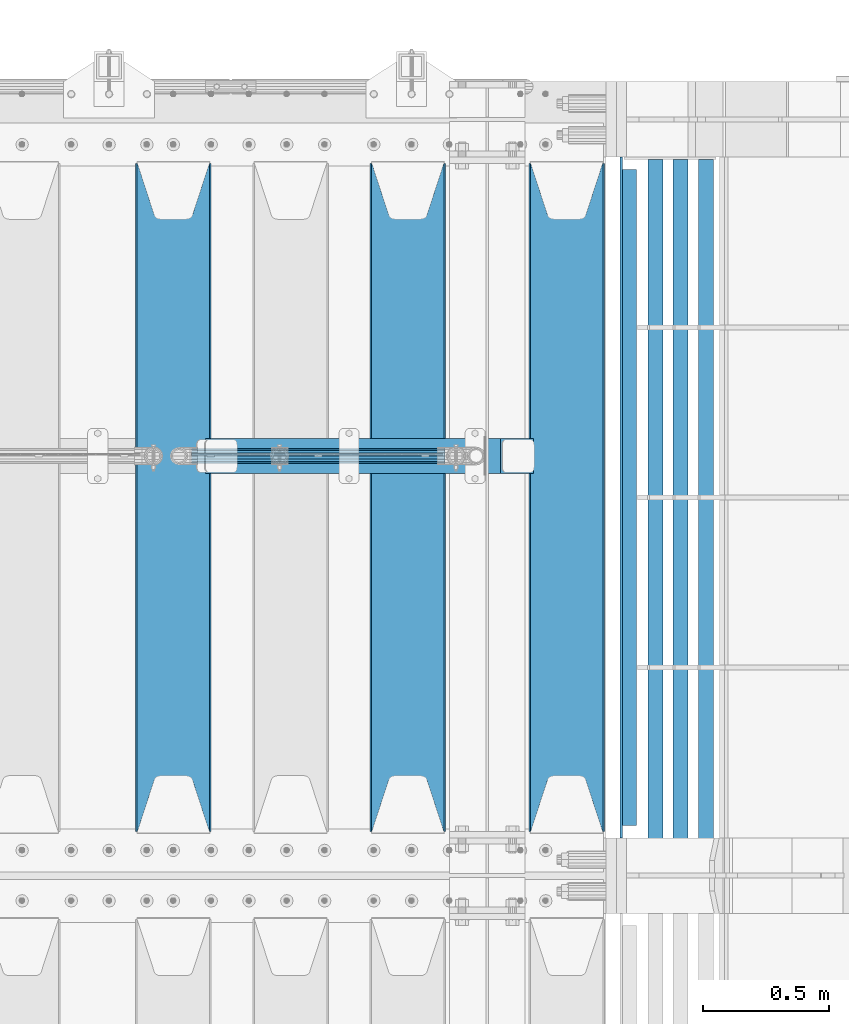
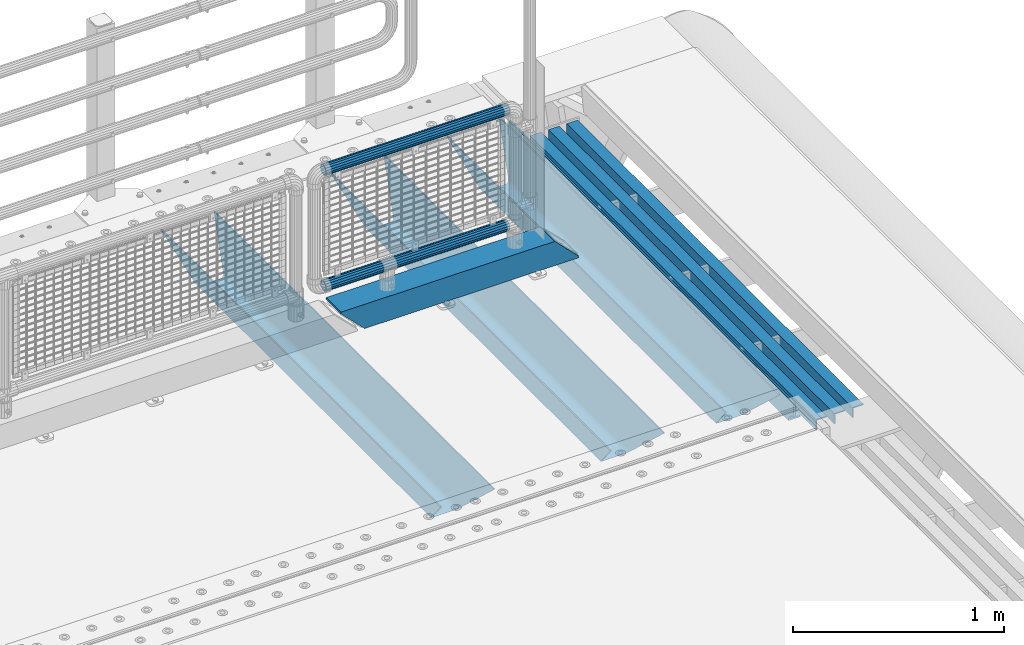
# One storey, part 111 of 208: 10 beams.
"""IFC2X3 building model written with IfcOpenShell, lengths in millimetres."""

from ifc_helpers import new_model, si_unit, frame, origin_with_axes, place, context, subcontext, project, spatial, faceted_brep, material, type_object, element, save


model = new_model("IFC2X3")

# Units and contexts
model_context = context("Model", 3, precision=1e-05, world=origin_with_axes())
body_context = subcontext(model_context, "Body", "Model", "MODEL_VIEW")
ifc_project = project(units=[si_unit("LENGTHUNIT", "METRE", prefix="MILLI"), si_unit("AREAUNIT", "SQUARE_METRE"), si_unit("VOLUMEUNIT", "CUBIC_METRE"), si_unit("MASSUNIT", "GRAM", prefix="KILO"), si_unit("TIMEUNIT", "SECOND"), si_unit("PLANEANGLEUNIT", "RADIAN"), si_unit("SOLIDANGLEUNIT", "STERADIAN"), si_unit("THERMODYNAMICTEMPERATUREUNIT", "DEGREE_CELSIUS"), si_unit("LUMINOUSINTENSITYUNIT", "LUMEN")], contexts=[model_context])

# Site, building, storey
site_placement = place(None, origin_with_axes())
site = spatial("IfcSite", under=ifc_project, at=site_placement, CompositionType="ELEMENT")
building_placement = place(site_placement, origin_with_axes())
building = spatial("IfcBuilding", under=site, at=building_placement, Name="Standard", CompositionType="ELEMENT")
storey_placement = place(building_placement, origin_with_axes())
storey = spatial("IfcBuildingStorey", under=building, at=storey_placement, Name="Undefined", CompositionType="ELEMENT", Elevation=0.0)

# Beams
ifc_material_1 = material(Name="STEEL/S355N")
beam_type_1 = type_object("IfcBeamType", PredefinedType="NOTDEFINED")
beam_1_placement = place(storey_placement, frame((-25790.0, 3175.0, -115.0), z_axis=(0.0, 0.0, 1.0), x_axis=(0.0, 1.0, 0.0)))
element("IfcBeam", 1, at=beam_1_placement, inside=storey, type_object=beam_type_1, material=ifc_material_1, context=body_context, shape_type="Brep", body=[
    faceted_brep([(0.0, 150.0, 115.0), (0.0, 143.689999999999, 115.0), (2650.00000000297, 143.689999999999, 115.0), (2650.00000000297, 150.0, 115.0), (2650.00000000297, 142.059565218402, 110.0000000031), (2650.00000000297, 148.369565218403, 110.0000000031), (2441.90079219208, -80.1103600731112, -98.0992078077845), (2437.7588105432, -77.5672621345584, -102.241189456673), (2434.06523489746, -74.4080125315522, -105.934765102404), (2430.91086095089, -70.710272125576, -109.089139048974), (2428.37322971128, -66.5649389910068, -111.626770288588), (2426.51472138055, -62.0739139532889, -113.485278619323), (2425.38102192091, -57.3475956567672, -114.618978078955), (2424.99999999987, -52.5021667386536, -115.0), (2424.99999999987, 52.5021667386536, -115.0), (2425.38102192091, 57.3475956567672, -114.618978078955), (2426.51472138055, 62.0739139532889, -113.485278619323), (2428.37322971128, 66.5649389910068, -111.626770288588), (2430.91086095089, 70.710272125576, -109.089139048974), (2434.06523489746, 74.4080125315522, -105.934765102404), (2437.7588105432, 77.5672621345584, -102.241189456673), (2441.90079219208, 80.1103600731112, -98.0992078077846), (2446.38936140511, 81.9747917625791, -93.6106385947584), (2448.24948500409, 76.2713538057251, -91.7505149957729), (2444.62967112262, 74.76777986261, -95.3703288772456), (2441.28936334126, 72.7168944282894, -98.710636658607), (2438.31067330438, 70.1691124903846, -101.689326695487), (2435.76682334747, 67.1870637758839, -104.233176652398), (2433.72034654133, 63.8440531834895, -106.279653458539), (2432.22154950041, 60.222258798236, -107.778450499454), (2431.30727574265, 56.4107117849089, -108.692724257221), (2430.99999999987, 52.5031078186876, -109.0), (2430.99999999987, -52.5031078186876, -109.0), (2431.30727574265, -56.4107117849089, -108.692724257221), (2432.22154950041, -60.222258798236, -107.778450499454), (2433.72034654133, -63.8440531834895, -106.279653458539), (2435.76682334747, -67.1870637758839, -104.233176652398), (2438.31067330438, -70.1691124903846, -101.689326695487), (2441.28936334126, -72.7168944282894, -98.7106366586071), (2444.62967112262, -74.76777986261, -95.3703288772457), (2448.24948500409, -76.2713538057251, -91.7505149957729), (2650.00000000297, -142.059565218402, 110.0000000031), (2650.00000000297, -148.369565218403, 110.0000000031), (2446.38936140511, -81.9747917625791, -93.6106385947584), (2650.00000000297, -143.689999999999, 115.0), (2650.00000000297, -150.0, 115.0), (0.0, -143.689999999999, 115.0), (0.0, -150.0, 115.0), (0.0, -148.369565218261, 110.000000002663), (203.610638597421, -81.9747917625791, -93.6106385947584), (208.099207810448, -80.1103600731112, -98.0992078077845), (212.241189459336, -77.5672621345584, -102.241189456673), (215.934765105067, -74.4080125315522, -105.934765102404), (219.089139051637, -70.710272125576, -109.089139048974), (221.626770291251, -66.5649389910068, -111.626770288588), (223.485278621986, -62.0739139532889, -113.485278619323), (224.618978081618, -57.3475956567672, -114.618978078955), (225.000000002663, -52.5021667386536, -115.0), (225.000000002663, 52.5021667386536, -115.0), (224.618978081618, 57.3475956567672, -114.618978078955), (223.485278621986, 62.0739139532889, -113.485278619323), (221.626770291251, 66.5649389910068, -111.626770288588), (219.089139051637, 70.710272125576, -109.089139048974), (215.934765105067, 74.4080125315522, -105.934765102404), (212.241189459336, 77.5672621345584, -102.241189456673), (208.099207810448, 80.1103600731112, -98.0992078077846), (203.610638597421, 81.9747917625791, -93.6106385947584), (0.0, 148.369565218261, 110.000000002663), (0.0, 142.05956521826, 110.000000002663), (201.750514998436, 76.2713538057251, -91.7505149957729), (205.370328879908, 74.76777986261, -95.3703288772456), (208.71063666127, 72.7168944282894, -98.710636658607), (211.68932669815, 70.1691124903846, -101.689326695487), (214.233176655061, 67.1870637758839, -104.233176652398), (216.279653461202, 63.8440531834895, -106.279653458539), (217.778450502116, 60.222258798236, -107.778450499454), (218.692724259884, 56.4107117849089, -108.692724257221), (219.000000002663, 52.5031078186876, -109.0), (219.000000002663, -52.5031078186876, -109.0), (218.692724259884, -56.4107117849089, -108.692724257221), (217.778450502116, -60.222258798236, -107.778450499454), (216.279653461202, -63.8440531834895, -106.279653458539), (214.233176655061, -67.1870637758839, -104.233176652398), (211.68932669815, -70.1691124903846, -101.689326695487), (208.71063666127, -72.7168944282894, -98.7106366586071), (205.370328879908, -74.76777986261, -95.3703288772457), (201.750514998436, -76.2713538057251, -91.7505149957729), (0.0, -142.05956521826, 110.000000002663)], [[[0, 1, 2, 3]], [[3, 2, 4, 5]], [[6, 7, 8, 9, 10, 11, 12, 13, 14, 15, 16, 17, 18, 19, 20, 21, 22, 5, 4, 23, 24, 25, 26, 27, 28, 29, 30, 31, 32, 33, 34, 35, 36, 37, 38, 39, 40, 41, 42, 43]], [[44, 45, 42, 41]], [[46, 47, 45, 44]], [[43, 42, 45, 47, 48, 49]], [[6, 43, 49, 50]], [[7, 6, 50, 51]], [[8, 7, 51, 52]], [[9, 8, 52, 53]], [[10, 9, 53, 54]], [[11, 10, 54, 55]], [[12, 11, 55, 56]], [[13, 12, 56, 57]], [[14, 13, 57, 58]], [[15, 14, 58, 59]], [[16, 15, 59, 60]], [[17, 16, 60, 61]], [[18, 17, 61, 62]], [[19, 18, 62, 63]], [[20, 19, 63, 64]], [[21, 20, 64, 65]], [[22, 21, 65, 66]], [[0, 3, 5, 22, 66, 67]], [[1, 0, 67, 68]], [[23, 4, 2, 1, 68, 69]], [[24, 23, 69, 70]], [[25, 24, 70, 71]], [[26, 25, 71, 72]], [[27, 26, 72, 73]], [[28, 27, 73, 74]], [[29, 28, 74, 75]], [[30, 29, 75, 76]], [[31, 30, 76, 77]], [[32, 31, 77, 78]], [[33, 32, 78, 79]], [[34, 33, 79, 80]], [[35, 34, 80, 81]], [[36, 35, 81, 82]], [[37, 36, 82, 83]], [[38, 37, 83, 84]], [[39, 38, 84, 85]], [[40, 39, 85, 86]], [[46, 44, 41, 40, 86, 87]], [[47, 46, 87, 48]], [[86, 85, 84, 83, 82, 81, 80, 79, 78, 77, 76, 75, 74, 73, 72, 71, 70, 69, 68, 67, 66, 65, 64, 63, 62, 61, 60, 59, 58, 57, 56, 55, 54, 53, 52, 51, 50, 49, 48, 87]]]),
])
beam_2_placement = place(storey_placement, frame((-26420.0, 3175.0, -115.0), z_axis=(0.0, 0.0, 1.0), x_axis=(0.0, 1.0, 0.0)))
element("IfcBeam", 2, at=beam_2_placement, inside=storey, type_object=beam_type_1, material=ifc_material_1, context=body_context, shape_type="Brep", body=[
    faceted_brep([(0.0, 150.0, 115.0), (0.0, 143.689999999999, 115.0), (2650.00000000297, 143.689999999999, 115.0), (2650.00000000297, 150.0, 115.0), (2650.00000000297, 142.059565218402, 110.0000000031), (2650.00000000297, 148.369565218403, 110.0000000031), (2441.90079219208, -80.1103600731112, -98.0992078077845), (2437.7588105432, -77.5672621345584, -102.241189456673), (2434.06523489746, -74.4080125315522, -105.934765102404), (2430.91086095089, -70.710272125576, -109.089139048974), (2428.37322971128, -66.5649389910068, -111.626770288588), (2426.51472138055, -62.0739139532889, -113.485278619323), (2425.38102192091, -57.3475956567672, -114.618978078955), (2424.99999999987, -52.5021667386536, -115.0), (2424.99999999987, 52.5021667386536, -115.0), (2425.38102192091, 57.3475956567672, -114.618978078955), (2426.51472138055, 62.0739139532889, -113.485278619323), (2428.37322971128, 66.5649389910068, -111.626770288588), (2430.91086095089, 70.710272125576, -109.089139048974), (2434.06523489746, 74.4080125315522, -105.934765102404), (2437.7588105432, 77.5672621345584, -102.241189456673), (2441.90079219208, 80.1103600731112, -98.0992078077846), (2446.38936140511, 81.9747917625791, -93.6106385947584), (2448.24948500409, 76.2713538057251, -91.7505149957729), (2444.62967112262, 74.76777986261, -95.3703288772456), (2441.28936334126, 72.7168944282894, -98.710636658607), (2438.31067330438, 70.1691124903846, -101.689326695487), (2435.76682334747, 67.1870637758839, -104.233176652398), (2433.72034654133, 63.8440531834895, -106.279653458539), (2432.22154950041, 60.222258798236, -107.778450499454), (2431.30727574265, 56.4107117849089, -108.692724257221), (2430.99999999987, 52.5031078186876, -109.0), (2430.99999999987, -52.5031078186876, -109.0), (2431.30727574265, -56.4107117849089, -108.692724257221), (2432.22154950041, -60.222258798236, -107.778450499454), (2433.72034654133, -63.8440531834895, -106.279653458539), (2435.76682334747, -67.1870637758839, -104.233176652398), (2438.31067330438, -70.1691124903846, -101.689326695487), (2441.28936334126, -72.7168944282894, -98.7106366586071), (2444.62967112262, -74.76777986261, -95.3703288772457), (2448.24948500409, -76.2713538057251, -91.7505149957729), (2650.00000000297, -142.059565218402, 110.0000000031), (2650.00000000297, -148.369565218403, 110.0000000031), (2446.38936140511, -81.9747917625791, -93.6106385947584), (2650.00000000297, -143.689999999999, 115.0), (2650.00000000297, -150.0, 115.0), (0.0, -143.689999999999, 115.0), (0.0, -150.0, 115.0), (0.0, -148.369565218261, 110.000000002663), (203.610638597421, -81.9747917625791, -93.6106385947584), (208.099207810448, -80.1103600731112, -98.0992078077845), (212.241189459336, -77.5672621345584, -102.241189456673), (215.934765105067, -74.4080125315522, -105.934765102404), (219.089139051637, -70.710272125576, -109.089139048974), (221.626770291251, -66.5649389910068, -111.626770288588), (223.485278621986, -62.0739139532889, -113.485278619323), (224.618978081618, -57.3475956567672, -114.618978078955), (225.000000002663, -52.5021667386536, -115.0), (225.000000002663, 52.5021667386536, -115.0), (224.618978081618, 57.3475956567672, -114.618978078955), (223.485278621986, 62.0739139532889, -113.485278619323), (221.626770291251, 66.5649389910068, -111.626770288588), (219.089139051637, 70.710272125576, -109.089139048974), (215.934765105067, 74.4080125315522, -105.934765102404), (212.241189459336, 77.5672621345584, -102.241189456673), (208.099207810448, 80.1103600731112, -98.0992078077846), (203.610638597421, 81.9747917625791, -93.6106385947584), (0.0, 148.369565218261, 110.000000002663), (0.0, 142.05956521826, 110.000000002663), (201.750514998436, 76.2713538057251, -91.7505149957729), (205.370328879908, 74.76777986261, -95.3703288772456), (208.71063666127, 72.7168944282894, -98.710636658607), (211.68932669815, 70.1691124903846, -101.689326695487), (214.233176655061, 67.1870637758839, -104.233176652398), (216.279653461202, 63.8440531834895, -106.279653458539), (217.778450502116, 60.222258798236, -107.778450499454), (218.692724259884, 56.4107117849089, -108.692724257221), (219.000000002663, 52.5031078186876, -109.0), (219.000000002663, -52.5031078186876, -109.0), (218.692724259884, -56.4107117849089, -108.692724257221), (217.778450502116, -60.222258798236, -107.778450499454), (216.279653461202, -63.8440531834895, -106.279653458539), (214.233176655061, -67.1870637758839, -104.233176652398), (211.68932669815, -70.1691124903846, -101.689326695487), (208.71063666127, -72.7168944282894, -98.7106366586071), (205.370328879908, -74.76777986261, -95.3703288772457), (201.750514998436, -76.2713538057251, -91.7505149957729), (0.0, -142.05956521826, 110.000000002663)], [[[0, 1, 2, 3]], [[3, 2, 4, 5]], [[6, 7, 8, 9, 10, 11, 12, 13, 14, 15, 16, 17, 18, 19, 20, 21, 22, 5, 4, 23, 24, 25, 26, 27, 28, 29, 30, 31, 32, 33, 34, 35, 36, 37, 38, 39, 40, 41, 42, 43]], [[44, 45, 42, 41]], [[46, 47, 45, 44]], [[43, 42, 45, 47, 48, 49]], [[6, 43, 49, 50]], [[7, 6, 50, 51]], [[8, 7, 51, 52]], [[9, 8, 52, 53]], [[10, 9, 53, 54]], [[11, 10, 54, 55]], [[12, 11, 55, 56]], [[13, 12, 56, 57]], [[14, 13, 57, 58]], [[15, 14, 58, 59]], [[16, 15, 59, 60]], [[17, 16, 60, 61]], [[18, 17, 61, 62]], [[19, 18, 62, 63]], [[20, 19, 63, 64]], [[21, 20, 64, 65]], [[22, 21, 65, 66]], [[0, 3, 5, 22, 66, 67]], [[1, 0, 67, 68]], [[23, 4, 2, 1, 68, 69]], [[24, 23, 69, 70]], [[25, 24, 70, 71]], [[26, 25, 71, 72]], [[27, 26, 72, 73]], [[28, 27, 73, 74]], [[29, 28, 74, 75]], [[30, 29, 75, 76]], [[31, 30, 76, 77]], [[32, 31, 77, 78]], [[33, 32, 78, 79]], [[34, 33, 79, 80]], [[35, 34, 80, 81]], [[36, 35, 81, 82]], [[37, 36, 82, 83]], [[38, 37, 83, 84]], [[39, 38, 84, 85]], [[40, 39, 85, 86]], [[46, 44, 41, 40, 86, 87]], [[47, 46, 87, 48]], [[86, 85, 84, 83, 82, 81, 80, 79, 78, 77, 76, 75, 74, 73, 72, 71, 70, 69, 68, 67, 66, 65, 64, 63, 62, 61, 60, 59, 58, 57, 56, 55, 54, 53, 52, 51, 50, 49, 48, 87]]]),
])
beam_3_placement = place(storey_placement, frame((-27350.0, 3175.0, -115.0), z_axis=(0.0, 0.0, 1.0), x_axis=(0.0, 1.0, 0.0)))
element("IfcBeam", 3, at=beam_3_placement, inside=storey, type_object=beam_type_1, material=ifc_material_1, context=body_context, shape_type="Brep", body=[
    faceted_brep([(0.0, 150.0, 115.0), (0.0, 143.689999999999, 115.0), (2650.00000000297, 143.689999999999, 115.0), (2650.00000000297, 150.0, 115.0), (2650.00000000297, 142.059565218402, 110.0000000031), (2650.00000000297, 148.369565218403, 110.0000000031), (2441.90079219208, -80.1103600731112, -98.0992078077845), (2437.7588105432, -77.5672621345584, -102.241189456673), (2434.06523489746, -74.4080125315522, -105.934765102404), (2430.91086095089, -70.710272125576, -109.089139048974), (2428.37322971128, -66.5649389910068, -111.626770288588), (2426.51472138055, -62.0739139532889, -113.485278619323), (2425.38102192091, -57.3475956567672, -114.618978078955), (2424.99999999987, -52.5021667386536, -115.0), (2424.99999999987, 52.5021667386536, -115.0), (2425.38102192091, 57.3475956567672, -114.618978078955), (2426.51472138055, 62.0739139532889, -113.485278619323), (2428.37322971128, 66.5649389910068, -111.626770288588), (2430.91086095089, 70.710272125576, -109.089139048974), (2434.06523489746, 74.4080125315522, -105.934765102404), (2437.7588105432, 77.5672621345584, -102.241189456673), (2441.90079219208, 80.1103600731112, -98.0992078077846), (2446.38936140511, 81.9747917625791, -93.6106385947584), (2448.24948500409, 76.2713538057251, -91.7505149957729), (2444.62967112262, 74.76777986261, -95.3703288772456), (2441.28936334126, 72.7168944282894, -98.710636658607), (2438.31067330438, 70.1691124903846, -101.689326695487), (2435.76682334747, 67.1870637758839, -104.233176652398), (2433.72034654133, 63.8440531834895, -106.279653458539), (2432.22154950041, 60.222258798236, -107.778450499454), (2431.30727574265, 56.4107117849089, -108.692724257221), (2430.99999999987, 52.5031078186876, -109.0), (2430.99999999987, -52.5031078186876, -109.0), (2431.30727574265, -56.4107117849089, -108.692724257221), (2432.22154950041, -60.222258798236, -107.778450499454), (2433.72034654133, -63.8440531834895, -106.279653458539), (2435.76682334747, -67.1870637758839, -104.233176652398), (2438.31067330438, -70.1691124903846, -101.689326695487), (2441.28936334126, -72.7168944282894, -98.7106366586071), (2444.62967112262, -74.76777986261, -95.3703288772457), (2448.24948500409, -76.2713538057251, -91.7505149957729), (2650.00000000297, -142.059565218402, 110.0000000031), (2650.00000000297, -148.369565218403, 110.0000000031), (2446.38936140511, -81.9747917625791, -93.6106385947584), (2650.00000000297, -143.689999999999, 115.0), (2650.00000000297, -150.0, 115.0), (0.0, -143.689999999999, 115.0), (0.0, -150.0, 115.0), (0.0, -148.369565218261, 110.000000002663), (203.610638597421, -81.9747917625791, -93.6106385947584), (208.099207810448, -80.1103600731112, -98.0992078077845), (212.241189459336, -77.5672621345584, -102.241189456673), (215.934765105067, -74.4080125315522, -105.934765102404), (219.089139051637, -70.710272125576, -109.089139048974), (221.626770291251, -66.5649389910068, -111.626770288588), (223.485278621986, -62.0739139532889, -113.485278619323), (224.618978081618, -57.3475956567672, -114.618978078955), (225.000000002663, -52.5021667386536, -115.0), (225.000000002663, 52.5021667386536, -115.0), (224.618978081618, 57.3475956567672, -114.618978078955), (223.485278621986, 62.0739139532889, -113.485278619323), (221.626770291251, 66.5649389910068, -111.626770288588), (219.089139051637, 70.710272125576, -109.089139048974), (215.934765105067, 74.4080125315522, -105.934765102404), (212.241189459336, 77.5672621345584, -102.241189456673), (208.099207810448, 80.1103600731112, -98.0992078077846), (203.610638597421, 81.9747917625791, -93.6106385947584), (0.0, 148.369565218261, 110.000000002663), (0.0, 142.05956521826, 110.000000002663), (201.750514998436, 76.2713538057251, -91.7505149957729), (205.370328879908, 74.76777986261, -95.3703288772456), (208.71063666127, 72.7168944282894, -98.710636658607), (211.68932669815, 70.1691124903846, -101.689326695487), (214.233176655061, 67.1870637758839, -104.233176652398), (216.279653461202, 63.8440531834895, -106.279653458539), (217.778450502116, 60.222258798236, -107.778450499454), (218.692724259884, 56.4107117849089, -108.692724257221), (219.000000002663, 52.5031078186876, -109.0), (219.000000002663, -52.5031078186876, -109.0), (218.692724259884, -56.4107117849089, -108.692724257221), (217.778450502116, -60.222258798236, -107.778450499454), (216.279653461202, -63.8440531834895, -106.279653458539), (214.233176655061, -67.1870637758839, -104.233176652398), (211.68932669815, -70.1691124903846, -101.689326695487), (208.71063666127, -72.7168944282894, -98.7106366586071), (205.370328879908, -74.76777986261, -95.3703288772457), (201.750514998436, -76.2713538057251, -91.7505149957729), (0.0, -142.05956521826, 110.000000002663)], [[[0, 1, 2, 3]], [[3, 2, 4, 5]], [[6, 7, 8, 9, 10, 11, 12, 13, 14, 15, 16, 17, 18, 19, 20, 21, 22, 5, 4, 23, 24, 25, 26, 27, 28, 29, 30, 31, 32, 33, 34, 35, 36, 37, 38, 39, 40, 41, 42, 43]], [[44, 45, 42, 41]], [[46, 47, 45, 44]], [[43, 42, 45, 47, 48, 49]], [[6, 43, 49, 50]], [[7, 6, 50, 51]], [[8, 7, 51, 52]], [[9, 8, 52, 53]], [[10, 9, 53, 54]], [[11, 10, 54, 55]], [[12, 11, 55, 56]], [[13, 12, 56, 57]], [[14, 13, 57, 58]], [[15, 14, 58, 59]], [[16, 15, 59, 60]], [[17, 16, 60, 61]], [[18, 17, 61, 62]], [[19, 18, 62, 63]], [[20, 19, 63, 64]], [[21, 20, 64, 65]], [[22, 21, 65, 66]], [[0, 3, 5, 22, 66, 67]], [[1, 0, 67, 68]], [[23, 4, 2, 1, 68, 69]], [[24, 23, 69, 70]], [[25, 24, 70, 71]], [[26, 25, 71, 72]], [[27, 26, 72, 73]], [[28, 27, 73, 74]], [[29, 28, 74, 75]], [[30, 29, 75, 76]], [[31, 30, 76, 77]], [[32, 31, 77, 78]], [[33, 32, 78, 79]], [[34, 33, 79, 80]], [[35, 34, 80, 81]], [[36, 35, 81, 82]], [[37, 36, 82, 83]], [[38, 37, 83, 84]], [[39, 38, 84, 85]], [[40, 39, 85, 86]], [[46, 44, 41, 40, 86, 87]], [[47, 46, 87, 48]], [[86, 85, 84, 83, 82, 81, 80, 79, 78, 77, 76, 75, 74, 73, 72, 71, 70, 69, 68, 67, 66, 65, 64, 63, 62, 61, 60, 59, 58, 57, 56, 55, 54, 53, 52, 51, 50, 49, 48, 87]]]),
])
ifc_material_2 = material()
beam_type_2 = type_object("IfcBeamType", PredefinedType="NOTDEFINED")
beam_4_placement = place(storey_placement, frame((-27223.0, 4664.5, 98.0199999999977), z_axis=(0.0, 0.0, 1.0), x_axis=(1.0, 0.0, 0.0)))
element("IfcBeam", 4, at=beam_4_placement, inside=storey, type_object=beam_type_2, material=ifc_material_2, context=body_context, shape_type="Brep", body=[
    faceted_brep([(0.0, 70.0, 70.0), (0.0, -70.0, 70.0), (1170.88846984782, -70.0, 70.0), (1170.88846984782, 70.0, 70.0), (1301.0, -60.0, -60.0), (1301.0, 60.0, -60.0), (119.989831466442, 60.0, -60.0), (119.989910626176, -60.0, -60.0), (1180.89643628727, -60.0, 60.0), (2.49929144047201e-09, -59.9999999999995, 60.0), (2.49929144047201e-09, 60.0000000000005, 60.0), (1180.89643628727, 60.0, 60.0), (1301.0, -70.0, -60.0079600980746), (1301.0, 70.0, -60.0079600980746), (1301.0, -70.0, -70.0), (1301.0, 70.0, -70.0), (129.999907566686, 70.0, -70.0), (0.0, 70.0, 59.8689646261584), (0.0, -70.0, 59.8690568861577), (129.99999991971, -70.0, -70.0)], [[[0, 1, 2, 3]], [[4, 5, 6, 7]], [[8, 4, 7, 9]], [[9, 10, 11, 8]], [[5, 11, 10, 6]], [[2, 12, 4, 8, 11, 5, 13, 3]], [[4, 12, 14, 15, 13, 5]], [[0, 3, 13, 15, 16, 17]], [[9, 18, 1, 0, 17, 10]], [[14, 12, 2, 1, 18, 19]], [[15, 14, 19, 16]], [[18, 9, 7, 6, 10, 17, 16, 19]]]),
])
ifc_material_3 = material(Name="STEEL/S355J2")
beam_type_3 = type_object("IfcBeamType", PredefinedType="NOTDEFINED")
beam_5_placement = place(storey_placement, frame((-25545.4974739935, 3150.0, -124.999999999993), z_axis=(0.0, 0.0, 1.0), x_axis=(0.0, 1.0, 0.0)))
element("IfcBeam", 5, at=beam_5_placement, inside=storey, type_object=beam_type_3, material=ifc_material_3, context=body_context, shape_type="Brep", body=[
    faceted_brep([(2700.0, 22.5, -15.0), (2684.54915028125, 22.5000000000036, -17.4471741852423), (2684.54915028125, 32.5000000000036, -17.4471741852423), (2700.0, 32.5, -15.0), (2670.61073738538, 22.5000000000036, -24.5491502812526), (2670.61073738538, 32.5000000000036, -24.5491502812526), (2659.54915028125, 22.5000000000036, -35.6107373853764), (2659.54915028125, 32.5000000000036, -35.6107373853764), (2652.44717418524, 22.5000000000036, -49.5491502812526), (2652.44717418524, 32.5000000000036, -49.5491502812526), (2651.58384440324, -32.5, -55.0), (2650.0, -32.5, -65.0), (2650.0, 32.5, -65.0), (2651.58384440324, 22.5, -55.0), (0.0, 32.5, 65.0), (0.0, 22.5, 65.0), (2700.0, 22.5, 65.0), (2700.0, 32.5, 65.0), (0.0, 32.5, -15.0), (0.0, 22.5, -15.0), (15.4508497187474, 32.5, -17.4471741852423), (15.4508497187474, 22.5, -17.4471741852423), (29.3892626146236, 32.5, -24.5491502812526), (29.3892626146236, 22.5, -24.5491502812526), (40.4508497187473, 32.5, -35.6107373853764), (40.4508497187473, 22.5, -35.6107373853764), (47.5528258147577, 32.5, -49.5491502812526), (47.5528258147577, 22.5, -49.5491502812526), (50.0, -32.5, -65.0), (48.4161555967548, -32.5, -55.0), (48.4161555967548, 22.5, -55.0), (50.0, 32.5, -65.0)], [[[0, 1, 2, 3]], [[4, 5, 2, 1]], [[6, 7, 5, 4]], [[8, 9, 7, 6]], [[10, 11, 12, 9, 8, 13]], [[14, 15, 16, 17]], [[15, 14, 18, 19]], [[19, 18, 20, 21]], [[21, 20, 22, 23]], [[23, 22, 24, 25]], [[25, 24, 26, 27]], [[28, 29, 30, 27, 26, 31]], [[30, 29, 10, 13]], [[16, 15, 19, 21, 23, 25, 27, 30, 13, 8, 6, 4, 1, 0]], [[17, 16, 0, 3]], [[5, 7, 9, 12, 31, 26, 24, 22, 20, 18, 14, 17, 3, 2]], [[28, 31, 12, 11]], [[29, 28, 11, 10]]]),
])
beam_type_4 = type_object("IfcBeamType", PredefinedType="NOTDEFINED")
for number, where, z_axis, x_axis in (
    (6, (-25238.001170099, 5839.99990041423, -209.999999999564), (0.0, 0.0, -1.0), (0.0, -1.0, 0.0)),
    (7, (-25338.001170099, 5839.99990041426, -209.999999999564), (0.0, 0.0, -1.0), (0.0, -1.0, 0.0)),
    (8, (-25438.0011700997, 5840.0000023388, -209.999999999622), (0.0, 0.0, -1.0), (0.0, -1.0, 0.0)),
):
    element("IfcBeam", number, at=place(storey_placement, frame(where, z_axis=z_axis, x_axis=x_axis)), inside=storey, type_object=beam_type_4, material=ifc_material_3, context=body_context, shape_type="Brep", body=[
        faceted_brep([(4.54747350886464e-13, 30.0000000000036, -30.0), (4.54747350886464e-13, 30.0000000000036, 30.0000000000001), (2710.00017042501, 30.0000000000073, 30.0), (2710.00017042501, 30.0000000000073, -30.0), (4.54747350886464e-13, 24.0000000000036, 30.0), (2710.00017042501, 24.0000000000073, 30.0), (4.54747350886464e-13, 24.0000000000036, -24.0), (2710.00017042501, 24.0000000000073, -24.0), (4.54747350886464e-13, -29.9999999999964, -24.0), (2710.00017042501, -29.9999999999927, -24.0), (4.54747350886464e-13, -29.9999999999964, -30.0), (2710.00017042501, -29.9999999999927, -30.0)], [[[0, 1, 2, 3]], [[1, 4, 5, 2]], [[4, 6, 7, 5]], [[6, 8, 9, 7]], [[8, 10, 11, 9]], [[10, 0, 3, 11]], [[5, 7, 9, 11, 3, 2]], [[10, 8, 6, 4, 1, 0]]]),
    ])
beam_type_5 = type_object("IfcBeamType", PredefinedType="NOTDEFINED")
beam_6_placement = place(storey_placement, frame((-27278.4, 4664.5, 298.170000000001), z_axis=(0.0, 0.0, 1.0), x_axis=(1.0, 0.0, 0.0)))
element("IfcBeam", 9, at=beam_6_placement, inside=storey, type_object=beam_type_5, material=ifc_material_2, context=body_context, shape_type="Brep", body=[
    faceted_brep([(0.0, -25.3500000000004, 0.0), (0.0, -23.4203461491616, 9.70102501045403), (1005.0, -23.4203461491616, 9.70102501045506), (1005.0, -25.3500000000004, 0.0), (0.0, -17.9251569030794, 17.9251569030785), (1005.0, -17.9251569030794, 17.925156903079), (0.0, -9.70102501045494, 23.4203461491597), (1005.0, -9.70102501045494, 23.4203461491611), (0.0, 0.0, 25.3499999999985), (1005.0, 0.0, 25.35), (0.0, 9.70102501045494, 23.4203461491597), (1005.0, 9.70102501045494, 23.4203461491611), (0.0, 17.9251569030794, 17.9251569030785), (1005.0, 17.9251569030794, 17.925156903079), (0.0, 23.4203461491616, 9.70102501045403), (1005.0, 23.4203461491616, 9.701025010455), (0.0, 25.3500000000004, 0.0), (1005.0, 25.3500000000004, 0.0), (0.0, 23.4203461491616, -9.70102501045403), (1005.0, 23.4203461491616, -9.70102501045506), (0.0, 17.9251569030794, -17.9251569030785), (1005.0, 17.9251569030794, -17.925156903079), (0.0, 9.70102501045494, -23.4203461491597), (1005.0, 9.70102501045494, -23.4203461491611), (0.0, 0.0, -25.3499999999985), (1005.0, 0.0, -25.35), (0.0, -9.70102501045494, -23.4203461491597), (1005.0, -9.70102501045494, -23.4203461491611), (0.0, -17.9251569030794, -17.9251569030785), (1005.0, -17.9251569030794, -17.925156903079), (0.0, -23.4203461491616, -9.70102501045403), (1005.0, -23.4203461491616, -9.701025010455), (0.0, -30.1499999999996, 0.0), (0.0, -27.8549679052148, -11.5379054858058), (1005.0, -27.8549679052148, -11.5379054858075), (1005.0, -30.1499999999996, 0.0), (0.0, -21.3192694527743, -21.3192694527752), (1005.0, -21.3192694527743, -21.3192694527744), (0.0, -11.5379054858076, -27.8549679052157), (1005.0, -11.5379054858076, -27.8549679052153), (0.0, 0.0, -30.1500000000015), (1005.0, 0.0, -30.15), (0.0, 11.5379054858076, -27.8549679052157), (1005.0, 11.5379054858076, -27.8549679052153), (0.0, 21.3192694527743, -21.3192694527752), (1005.0, 21.3192694527743, -21.3192694527744), (0.0, 27.8549679052157, -11.5379054858058), (1005.0, 27.8549679052157, -11.5379054858075), (0.0, 30.1499999999996, 0.0), (1005.0, 30.1499999999996, 0.0), (0.0, 27.8549679052157, 11.5379054858058), (1005.0, 27.8549679052157, 11.5379054858075), (0.0, 21.3192694527743, 21.3192694527752), (1005.0, 21.3192694527743, 21.3192694527744), (0.0, 11.5379054858076, 27.8549679052157), (1005.0, 11.5379054858076, 27.8549679052153), (0.0, 0.0, 30.1500000000015), (1005.0, 0.0, 30.15), (0.0, -11.5379054858076, 27.8549679052157), (1005.0, -11.5379054858076, 27.8549679052153), (0.0, -21.3192694527743, 21.3192694527752), (1005.0, -21.3192694527743, 21.3192694527744), (0.0, -27.8549679052157, 11.5379054858058), (1005.0, -27.8549679052157, 11.5379054858075)], [[[0, 1, 2, 3]], [[1, 4, 5, 2]], [[4, 6, 7, 5]], [[6, 8, 9, 7]], [[8, 10, 11, 9]], [[10, 12, 13, 11]], [[12, 14, 15, 13]], [[14, 16, 17, 15]], [[16, 18, 19, 17]], [[18, 20, 21, 19]], [[20, 22, 23, 21]], [[22, 24, 25, 23]], [[24, 26, 27, 25]], [[26, 28, 29, 27]], [[28, 30, 31, 29]], [[30, 0, 3, 31]], [[32, 33, 34, 35]], [[33, 36, 37, 34]], [[36, 38, 39, 37]], [[38, 40, 41, 39]], [[40, 42, 43, 41]], [[42, 44, 45, 43]], [[44, 46, 47, 45]], [[46, 48, 49, 47]], [[48, 50, 51, 49]], [[50, 52, 53, 51]], [[52, 54, 55, 53]], [[54, 56, 57, 55]], [[56, 58, 59, 57]], [[58, 60, 61, 59]], [[60, 62, 63, 61]], [[62, 32, 35, 63]], [[37, 39, 41, 43, 45, 47, 49, 51, 53, 55, 57, 59, 61, 63, 35, 34], [5, 7, 9, 11, 13, 15, 17, 19, 21, 23, 25, 27, 29, 31, 3, 2]], [[62, 60, 58, 56, 54, 52, 50, 48, 46, 44, 42, 40, 38, 36, 33, 32], [30, 28, 26, 24, 22, 20, 18, 16, 14, 12, 10, 8, 6, 4, 1, 0]]]),
])
beam_7_placement = place(storey_placement, frame((-27279.0, 4664.5, 969.85), z_axis=(0.0, 0.0, 1.0), x_axis=(1.0, 0.0, 0.0)))
element("IfcBeam", 10, at=beam_7_placement, inside=storey, type_object=beam_type_5, material=ifc_material_2, context=body_context, shape_type="Brep", body=[
    faceted_brep([(0.0, -25.3500000000004, 0.0), (0.0, -23.4203461491616, 9.70102501045403), (1005.0, -23.4203461491616, 9.70102501045506), (1005.0, -25.3500000000004, 0.0), (0.0, -17.9251569030794, 17.9251569030785), (1005.0, -17.9251569030794, 17.925156903079), (0.0, -9.70102501045494, 23.4203461491597), (1005.0, -9.70102501045494, 23.4203461491611), (0.0, 0.0, 25.3499999999985), (1005.0, 0.0, 25.35), (0.0, 9.70102501045494, 23.4203461491597), (1005.0, 9.70102501045494, 23.4203461491611), (0.0, 17.9251569030794, 17.9251569030785), (1005.0, 17.9251569030794, 17.925156903079), (0.0, 23.4203461491616, 9.70102501045403), (1005.0, 23.4203461491616, 9.701025010455), (0.0, 25.3500000000004, 0.0), (1005.0, 25.3500000000004, 0.0), (0.0, 23.4203461491616, -9.70102501045403), (1005.0, 23.4203461491616, -9.70102501045506), (0.0, 17.9251569030794, -17.9251569030785), (1005.0, 17.9251569030794, -17.925156903079), (0.0, 9.70102501045494, -23.4203461491597), (1005.0, 9.70102501045494, -23.4203461491611), (0.0, 0.0, -25.3499999999985), (1005.0, 0.0, -25.35), (0.0, -9.70102501045494, -23.4203461491597), (1005.0, -9.70102501045494, -23.4203461491611), (0.0, -17.9251569030794, -17.9251569030785), (1005.0, -17.9251569030794, -17.925156903079), (0.0, -23.4203461491616, -9.70102501045403), (1005.0, -23.4203461491616, -9.701025010455), (0.0, -30.1499999999996, 0.0), (0.0, -27.8549679052148, -11.5379054858058), (1005.0, -27.8549679052148, -11.5379054858075), (1005.0, -30.1499999999996, 0.0), (0.0, -21.3192694527743, -21.3192694527752), (1005.0, -21.3192694527743, -21.3192694527744), (0.0, -11.5379054858076, -27.8549679052157), (1005.0, -11.5379054858076, -27.8549679052153), (0.0, 0.0, -30.1500000000015), (1005.0, 0.0, -30.15), (0.0, 11.5379054858076, -27.8549679052157), (1005.0, 11.5379054858076, -27.8549679052153), (0.0, 21.3192694527743, -21.3192694527752), (1005.0, 21.3192694527743, -21.3192694527744), (0.0, 27.8549679052157, -11.5379054858058), (1005.0, 27.8549679052157, -11.5379054858075), (0.0, 30.1499999999996, 0.0), (1005.0, 30.1499999999996, 0.0), (0.0, 27.8549679052157, 11.5379054858058), (1005.0, 27.8549679052157, 11.5379054858075), (0.0, 21.3192694527743, 21.3192694527752), (1005.0, 21.3192694527743, 21.3192694527744), (0.0, 11.5379054858076, 27.8549679052157), (1005.0, 11.5379054858076, 27.8549679052153), (0.0, 0.0, 30.1500000000015), (1005.0, 0.0, 30.15), (0.0, -11.5379054858076, 27.8549679052157), (1005.0, -11.5379054858076, 27.8549679052153), (0.0, -21.3192694527743, 21.3192694527752), (1005.0, -21.3192694527743, 21.3192694527744), (0.0, -27.8549679052157, 11.5379054858058), (1005.0, -27.8549679052157, 11.5379054858075)], [[[0, 1, 2, 3]], [[1, 4, 5, 2]], [[4, 6, 7, 5]], [[6, 8, 9, 7]], [[8, 10, 11, 9]], [[10, 12, 13, 11]], [[12, 14, 15, 13]], [[14, 16, 17, 15]], [[16, 18, 19, 17]], [[18, 20, 21, 19]], [[20, 22, 23, 21]], [[22, 24, 25, 23]], [[24, 26, 27, 25]], [[26, 28, 29, 27]], [[28, 30, 31, 29]], [[30, 0, 3, 31]], [[32, 33, 34, 35]], [[33, 36, 37, 34]], [[36, 38, 39, 37]], [[38, 40, 41, 39]], [[40, 42, 43, 41]], [[42, 44, 45, 43]], [[44, 46, 47, 45]], [[46, 48, 49, 47]], [[48, 50, 51, 49]], [[50, 52, 53, 51]], [[52, 54, 55, 53]], [[54, 56, 57, 55]], [[56, 58, 59, 57]], [[58, 60, 61, 59]], [[60, 62, 63, 61]], [[62, 32, 35, 63]], [[37, 39, 41, 43, 45, 47, 49, 51, 53, 55, 57, 59, 61, 63, 35, 34], [5, 7, 9, 11, 13, 15, 17, 19, 21, 23, 25, 27, 29, 31, 3, 2]], [[62, 60, 58, 56, 54, 52, 50, 48, 46, 44, 42, 40, 38, 36, 33, 32], [30, 28, 26, 24, 22, 20, 18, 16, 14, 12, 10, 8, 6, 4, 1, 0]]]),
])

save(model, "model.ifc")
